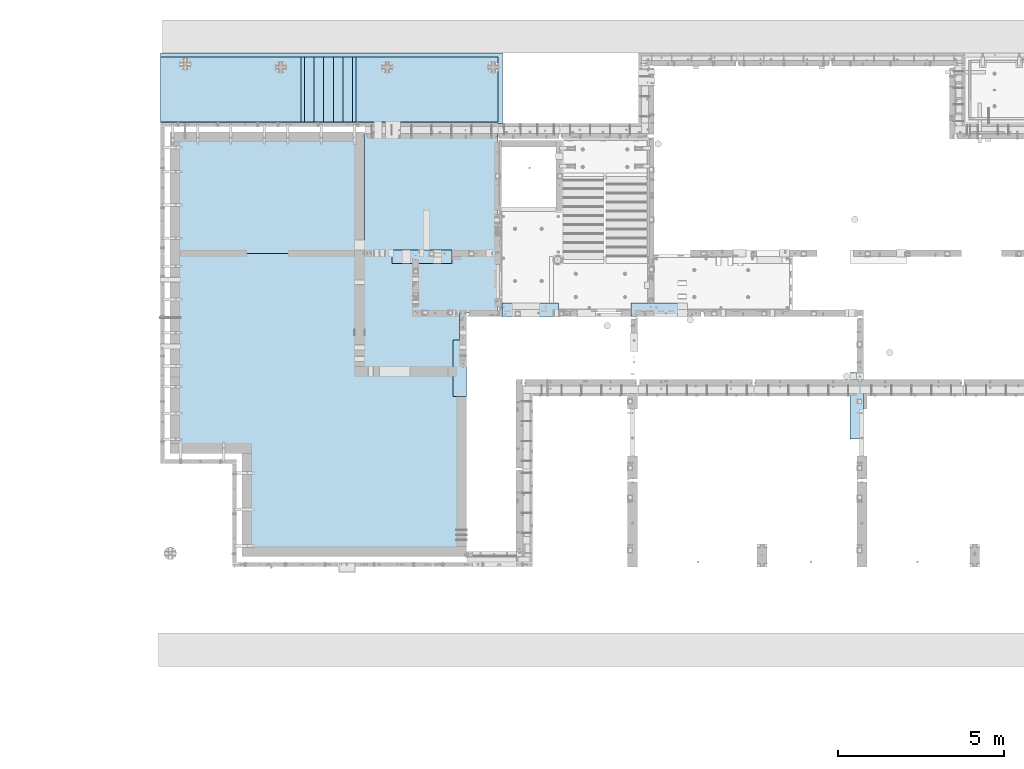
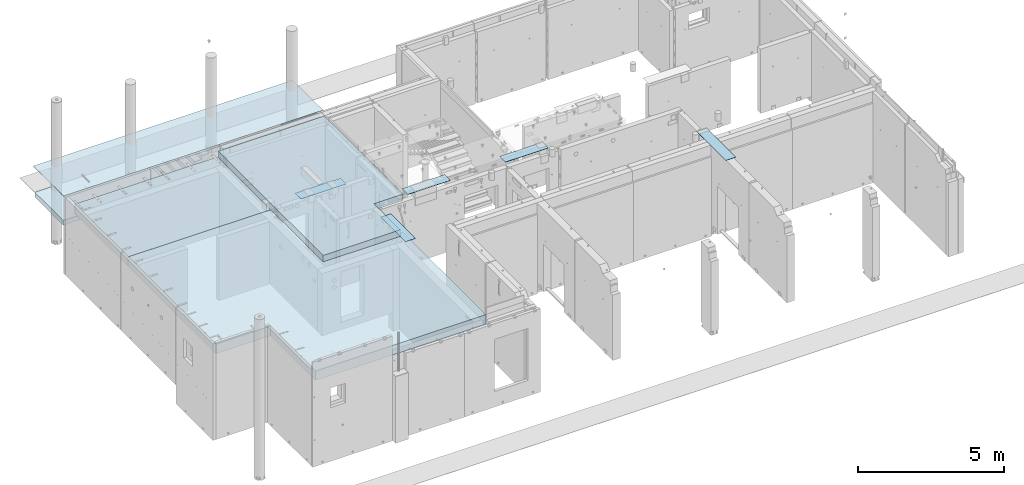
# One storey, part 147 of 264: 6 plates, 6 slabs, 12 elements without a shape of their own.
"""IFC2X3 building model written with IfcOpenShell, lengths in millimetres."""

from ifc_helpers import new_model, si_unit, frame, origin_with_axes, place, context, subcontext, project, spatial, faceted_brep, material, type_object, element, aggregate, save


model = new_model("IFC2X3")

# Units and contexts
model_context = context("Model", 3, precision=1e-05, world=origin_with_axes())
body_context = subcontext(model_context, "Body", "Model", "MODEL_VIEW")
ifc_project = project(units=[si_unit("LENGTHUNIT", "METRE", prefix="MILLI"), si_unit("AREAUNIT", "SQUARE_METRE"), si_unit("VOLUMEUNIT", "CUBIC_METRE"), si_unit("MASSUNIT", "GRAM", prefix="KILO"), si_unit("TIMEUNIT", "SECOND"), si_unit("PLANEANGLEUNIT", "RADIAN"), si_unit("SOLIDANGLEUNIT", "STERADIAN"), si_unit("THERMODYNAMICTEMPERATUREUNIT", "DEGREE_CELSIUS"), si_unit("LUMINOUSINTENSITYUNIT", "LUMEN")], contexts=[model_context])

# Site, building, storey
site_placement = place(None, origin_with_axes())
site = spatial("IfcSite", under=ifc_project, at=site_placement, CompositionType="ELEMENT")
building_placement = place(site_placement, origin_with_axes())
building = spatial("IfcBuilding", under=site, at=building_placement, CompositionType="ELEMENT")
storey_placement = place(building_placement, origin_with_axes())
storey = spatial("IfcBuildingStorey", under=building, at=storey_placement, Name="K", CompositionType="ELEMENT", Elevation=0.0)

# Assembly, plate
assembly_1_placement = place(storey_placement, origin_with_axes())
assembly_1 = element("IfcElementAssembly", 1, at=assembly_1_placement, inside=storey, Name="Steel Assembly", AssemblyPlace="NOTDEFINED", PredefinedType="NOTDEFINED")
ifc_material_1 = material()
plate_type_1 = type_object("IfcPlateType", PredefinedType="NOTDEFINED")
plate_1_placement = place(assembly_1_placement, frame((17842.0, 22999.95272079, 81715.0002235374), z_axis=(0.0, -0.999955292526699, 0.0094558419955201), x_axis=(-1.0, 3.00000001838171e-08, 0.0)))
plate_1 = element("IfcPlate", 2, at=plate_1_placement, type_object=plate_type_1, material=ifc_material_1, context=body_context, shape_type="Brep", body=[
    faceted_brep([(0.0, -5.0, 0.0), (0.00106528995092958, -5.0, 2115.09448242188), (0.00106528995092958, 5.0, 2115.09448242188), (0.0, 5.0, 0.0), (10282.0, -5.0, 2115.09448242188), (10282.0, 5.0, 2115.09448242188), (10282.0, -5.0, 0.0), (10282.0, 5.0, 3.63797880709171e-12)], [[[0, 1, 2, 3]], [[1, 4, 5, 2]], [[4, 6, 7, 5]], [[6, 0, 3, 7]], [[5, 7, 3, 2]], [[6, 4, 1, 0]]]),
])
aggregate(assembly_1, [plate_1])

# Assembly, slab
assembly_2_placement = place(storey_placement, origin_with_axes())
assembly_2 = element("IfcElementAssembly", 3, at=assembly_2_placement, inside=storey, Name="Assembly", AssemblyPlace="NOTDEFINED", PredefinedType="REINFORCEMENT_UNIT")
ifc_material_2 = material(Name="CONCRETE/Concrete_Undefined")
slab_type_1 = type_object("IfcSlabType", PredefinedType="NOTDEFINED")
slab_1_placement = place(assembly_2_placement, frame((11889.9993483948, 21907.9000655301, 80690.0), z_axis=(0.0, 0.0, -1.0), x_axis=(-1.0, 3.00000001838171e-08, 0.0)))
slab_1 = element("IfcSlab", 4, at=slab_1_placement, type_object=slab_type_1, material=ifc_material_2, Name="STAIRS", PredefinedType="FLOOR", context=body_context, shape_type="Brep", body=[
    faceted_brep([(0.0, -972.5, 0.0), (0.0, -972.5, -160.0), (1.81898940354586e-12, 972.5, -160.0), (1.81898940354586e-12, 972.5, 0.0), (-289.999267578125, -972.5, -160.0), (-289.999267578127, 972.500000000004, -160.0), (-289.999267578125, -972.5, -320.0), (-289.999267578127, 972.500000000004, -320.0), (-579.99853515625, -972.5, -320.0), (-579.99853515625, 972.500000000004, -320.0), (-579.99853515625, -972.5, -480.0), (-579.99853515625, 972.500000000004, -480.0), (-869.997802734373, -972.5, -480.0), (-869.997802734375, 972.5, -480.0), (-869.997802734373, -972.5, -640.0), (-869.997802734375, 972.5, -640.0), (-1159.9970703125, -972.5, -640.0), (-1159.9970703125, 972.500000000004, -640.0), (-1159.9970703125, -972.5, -800.0), (-1159.9970703125, 972.500000000004, -800.0), (-1449.99633789063, -972.5, -800.0), (-1449.99633789063, 972.5, -800.0), (-1449.99633789063, -972.5, -960.0), (-1449.99633789063, 972.5, -960.0), (-1549.99633789063, -972.5, -960.0), (-1549.99633789063, 972.5, -960.0), (-1549.99633789063, -972.5, -626.751770019531), (-1549.99633789063, 972.5, -626.751770019531), (-232.762039184568, -972.5, 100.0), (-232.762039184568, 972.500000000004, 100.0), (100.000000000002, -972.5, 100.0), (100.000000000002, 972.5, 100.0), (100.000000000002, -972.5, 0.0), (100.000000000002, 972.5, 0.0)], [[[0, 1, 2, 3]], [[1, 4, 5, 2]], [[4, 6, 7, 5]], [[6, 8, 9, 7]], [[8, 10, 11, 9]], [[10, 12, 13, 11]], [[12, 14, 15, 13]], [[14, 16, 17, 15]], [[16, 18, 19, 17]], [[18, 20, 21, 19]], [[20, 22, 23, 21]], [[22, 24, 25, 23]], [[24, 26, 27, 25]], [[26, 28, 29, 27]], [[28, 30, 31, 29]], [[30, 32, 33, 31]], [[32, 0, 3, 33]], [[5, 7, 9, 11, 13, 15, 17, 19, 21, 23, 25, 27, 29, 31, 33, 3, 2]], [[32, 30, 28, 26, 24, 22, 20, 18, 16, 14, 12, 10, 8, 6, 4, 1, 0]]]),
])
aggregate(assembly_2, [slab_1])

# Assembly, plate
assembly_3_placement = place(storey_placement, origin_with_axes())
assembly_3 = element("IfcElementAssembly", 5, at=assembly_3_placement, inside=storey, Name="Steel Assembly", AssemblyPlace="NOTDEFINED", PredefinedType="NOTDEFINED")
ifc_material_3 = material()
plate_type_2 = type_object("IfcPlateType", PredefinedType="NOTDEFINED")
plate_2_placement = place(assembly_3_placement, frame((17840.0, 15080.0, 81725.6000003815), z_axis=(0.0, 1.0, 0.0), x_axis=(1.0, 0.0, 0.0)))
plate_2 = element("IfcPlate", 6, at=plate_2_placement, type_object=plate_type_2, material=ifc_material_3, Name="YP", context=body_context, shape_type="Brep", body=[
    faceted_brep([(0.0, -5.0, 0.0), (0.0, -5.0, 400.0), (0.0, 5.0, 400.0), (0.0, 5.0, 0.0), (1699.99914550781, -5.0, 400.0), (1699.99914550781, 5.0, 400.0), (1699.99914550781, -5.0, 3.63797880709171e-12), (1699.99914550781, 5.0, 3.63797880709171e-12)], [[[0, 1, 2, 3]], [[1, 4, 5, 2]], [[4, 6, 7, 5]], [[6, 0, 3, 7]], [[5, 7, 3, 2]], [[6, 4, 1, 0]]]),
])
aggregate(assembly_3, [plate_2])

assembly_4_placement = place(storey_placement, origin_with_axes())
assembly_4 = element("IfcElementAssembly", 7, at=assembly_4_placement, inside=storey, Name="Steel Assembly", AssemblyPlace="NOTDEFINED", PredefinedType="NOTDEFINED")
plate_3_placement = place(assembly_4_placement, frame((21710.0, 15080.0, 81725.6000003815), z_axis=(0.0, 1.0, 0.0), x_axis=(1.0, 0.0, 0.0)))
plate_3 = element("IfcPlate", 8, at=plate_3_placement, type_object=plate_type_2, material=ifc_material_3, Name="YP", context=body_context, shape_type="Brep", body=[
    faceted_brep([(0.0, -5.0, 0.0), (0.0, -5.0, 400.0), (0.0, 5.0, 400.0), (0.0, 5.0, 0.0), (1699.99914550781, -5.0, 400.0), (1699.99914550781, 5.0, 400.0), (1699.99914550781, -5.0, 3.63797880709171e-12), (1699.99914550781, 5.0, 3.63797880709171e-12)], [[[0, 1, 2, 3]], [[1, 4, 5, 2]], [[4, 6, 7, 5]], [[6, 0, 3, 7]], [[5, 7, 3, 2]], [[6, 4, 1, 0]]]),
])
aggregate(assembly_4, [plate_3])

assembly_5_placement = place(storey_placement, origin_with_axes())
assembly_5 = element("IfcElementAssembly", 9, at=assembly_5_placement, inside=storey, Name="Steel Assembly", AssemblyPlace="NOTDEFINED", PredefinedType="NOTDEFINED")
plate_4_placement = place(assembly_5_placement, frame((14530.0, 16680.0, 81725.6000003815), z_axis=(0.0, 1.0, 0.0), x_axis=(1.0, 0.0, 0.0)))
plate_4 = element("IfcPlate", 10, at=plate_4_placement, type_object=plate_type_2, material=ifc_material_3, Name="YP", context=body_context, shape_type="Brep", body=[
    faceted_brep([(0.0, -5.0, 0.0), (0.0, -5.0, 400.0), (0.0, 5.0, 400.0), (0.0, 5.0, 0.0), (1799.99914550781, -5.0, 400.0), (1799.99914550781, 5.0, 400.0), (1799.99914550781, -5.0, 3.63797880709171e-12), (1799.99914550781, 5.0, 3.63797880709171e-12)], [[[0, 1, 2, 3]], [[1, 4, 5, 2]], [[4, 6, 7, 5]], [[6, 0, 3, 7]], [[5, 7, 3, 2]], [[6, 4, 1, 0]]]),
])
aggregate(assembly_5, [plate_4])

assembly_6_placement = place(storey_placement, origin_with_axes())
assembly_6 = element("IfcElementAssembly", 11, at=assembly_6_placement, inside=storey, Name="Steel Assembly", AssemblyPlace="NOTDEFINED", PredefinedType="NOTDEFINED")
plate_5_placement = place(assembly_6_placement, frame((28710.0, 11388.0, 81725.6000003815), z_axis=(-1.0, 3.00000001838171e-08, 0.0), x_axis=(0.0, 1.0, 0.0)))
plate_5 = element("IfcPlate", 12, at=plate_5_placement, type_object=plate_type_2, material=ifc_material_3, Name="YP", context=body_context, shape_type="Brep", body=[
    faceted_brep([(0.0, -5.0, 0.0), (0.0, -5.0, 400.0), (0.0, 5.0, 400.0), (0.0, 5.0, 0.0), (1999.99963378906, -5.0, 400.0), (1999.99963378906, 5.0, 400.0), (1999.99963378906, -5.0, 0.0), (1999.99963378906, 5.0, 0.0)], [[[0, 1, 2, 3]], [[1, 4, 5, 2]], [[4, 6, 7, 5]], [[6, 0, 3, 7]], [[5, 7, 3, 2]], [[6, 4, 1, 0]]]),
])
aggregate(assembly_6, [plate_5])

assembly_7_placement = place(storey_placement, origin_with_axes())
assembly_7 = element("IfcElementAssembly", 13, at=assembly_7_placement, inside=storey, Name="Steel Assembly", AssemblyPlace="NOTDEFINED", PredefinedType="NOTDEFINED")
plate_6_placement = place(assembly_7_placement, frame((16760.0, 12675.0, 81725.6000003815), z_axis=(-0.999999990476206, -0.000138013000065496, 0.0), x_axis=(-0.000138013000066464, 0.999999990476206, 0.0)))
plate_6 = element("IfcPlate", 14, at=plate_6_placement, type_object=plate_type_2, material=ifc_material_3, Name="YP", context=body_context, shape_type="Brep", body=[
    faceted_brep([(0.0, -5.0, 0.0), (0.0552374608814716, -5.0, 400.234619140625), (0.0552374608814716, 5.0, 400.234619140625), (0.0, 5.0, 0.0), (1700.05529785156, -5.0, 399.999999999998), (1700.05529785156, 5.0, 399.999999999998), (1700.00012207031, -5.0, 1.15687726065516e-09), (1700.00012207031, 5.0, 1.15687726065516e-09)], [[[0, 1, 2, 3]], [[1, 4, 5, 2]], [[4, 6, 7, 5]], [[6, 0, 3, 7]], [[5, 7, 3, 2]], [[6, 4, 1, 0]]]),
])
aggregate(assembly_7, [plate_6])

# Assembly, slab
assembly_8_placement = place(storey_placement, origin_with_axes())
assembly_8 = element("IfcElementAssembly", 15, at=assembly_8_placement, inside=storey, AssemblyPlace="NOTDEFINED", PredefinedType="REINFORCEMENT_UNIT")
slab_type_2 = type_object("IfcSlabType", PredefinedType="NOTDEFINED")
slab_2_placement = place(assembly_8_placement, frame((12208.7601086809, 22880.4000655301, 80590.0), z_axis=(0.0, -1.0, 0.0), x_axis=(-1.0, 3.00000001838171e-08, 0.0)))
slab_2 = element("IfcSlab", 16, at=slab_2_placement, type_object=slab_type_2, material=ifc_material_2, PredefinedType="FLOOR", context=body_context, shape_type="Brep", body=[
    faceted_brep([(418.760011883927, -100.0, 8.00355337560177e-11), (418.762007453937, -100.0, 1944.99981955335), (418.762007453937, 0.0, 1944.99981955335), (418.760011883929, 0.0, -0.000180445626028813), (0.000471908697363688, -100.0, 1945.00024920269), (0.000471809626105824, 0.0, 1945.00024920269), (-0.00152376038022339, 0.0, 0.000249203712883173), (0.000472005545816501, -100.0, 1945.3994140625), (4648.763671875, -100.0, 1945.39880371093), (4648.763671875, 100.0, 1945.39880371093), (0.000472005545816501, 100.0, 1945.3994140625), (4648.763671875, -100.0, 9.24046617001295e-10), (4648.763671875, 100.0, 9.24046617001295e-10), (0.0, 100.0, 0.0)], [[[0, 1, 2, 3]], [[4, 5, 2, 1]], [[6, 3, 2, 5]], [[7, 8, 9, 10]], [[8, 11, 12, 9]], [[9, 12, 13, 10]], [[4, 7, 10, 13, 6, 5]], [[0, 11, 8, 7, 4, 1]], [[13, 12, 11, 0, 3, 6]]]),
])
aggregate(assembly_8, [slab_2])

assembly_9_placement = place(storey_placement, origin_with_axes())
assembly_9 = element("IfcElementAssembly", 17, at=assembly_9_placement, inside=storey, AssemblyPlace="NOTDEFINED", PredefinedType="REINFORCEMENT_UNIT")
slab_3_placement = place(assembly_9_placement, frame((17720.0001086809, 22880.4000495535, 81550.0), z_axis=(0.0, -1.0, 0.0), x_axis=(-1.0, 3.00000001838171e-08, 0.0)))
slab_3 = element("IfcSlab", 18, at=slab_3_placement, type_object=slab_type_2, material=ifc_material_2, PredefinedType="FLOOR", context=body_context, shape_type="Brep", body=[
    faceted_brep([(4280.00363260356, -100.0, 0.000104388796899002), (4280.00363260357, 100.0, -6.78119249641895e-09), (4280.00564956835, 100.0, 1944.99879323152), (4280.00564956836, -100.0, 1944.99879323152), (0.0, -100.0, 0.0), (0.000493853753141593, -100.0, 1944.99938964844), (0.000493853753141593, 100.0, 1944.99938964844), (0.0, 100.0, 0.0)], [[[0, 1, 2, 3]], [[4, 5, 6, 7]], [[5, 4, 0, 3]], [[6, 5, 3, 2]], [[7, 6, 2, 1]], [[4, 7, 1, 0]]]),
])
aggregate(assembly_9, [slab_3])

assembly_10_placement = place(storey_placement, origin_with_axes())
assembly_10 = element("IfcElementAssembly", 19, at=assembly_10_placement, inside=storey, AssemblyPlace="NOTDEFINED", PredefinedType="REINFORCEMENT_UNIT")
ifc_material_4 = material(Name="CONCRETE/C30/37")
slab_type_3 = type_object("IfcSlabType", PredefinedType="NOTDEFINED")
slab_4_placement = place(assembly_10_placement, frame((13500.0033728411, 13375.0031738281, 81595.0), z_axis=(0.0, 1.0, 0.0), x_axis=(1.0, 0.0, 0.0)))
slab_4 = element("IfcSlab", 20, at=slab_4_placement, type_object=slab_type_3, material=ifc_material_4, PredefinedType="FLOOR", context=body_context, shape_type="Brep", body=[
    faceted_brep([(3059.99662716033, -135.0, 4.38376446254551e-10), (3059.99662716033, 135.0, 4.38376446254551e-10), (3059.99488714054, 135.0, 1804.99977600779), (3059.99488714054, -135.0, 1804.99977600779), (3159.99462890626, -135.0, 1804.99987240754), (3159.99462890625, 135.0, 1804.99987792969), (1.81898940354586e-12, -135.0, 1.81898940354586e-12), (-0.00694355741507025, -135.0, 7204.9970703125), (-0.00694355741507025, 135.0, 7204.9970703125), (1.81898940354586e-12, 135.0, 1.81898940354586e-12), (4209.99316406249, -135.0, 7205.0009765625), (4209.99316406249, 135.0, 7205.0009765625), (4209.9951171875, -135.0, 1805.00085449219), (4209.9951171875, 135.0, 1805.00085449219)], [[[0, 1, 2, 3]], [[4, 3, 2, 5]], [[6, 7, 8, 9]], [[7, 10, 11, 8]], [[10, 12, 13, 11]], [[12, 4, 5, 13]], [[1, 9, 8, 11, 13, 5, 2]], [[6, 9, 1, 0]], [[12, 10, 7, 6, 0, 3, 4]]]),
])
aggregate(assembly_10, [slab_4])

assembly_11_placement = place(storey_placement, origin_with_axes())
assembly_11 = element("IfcElementAssembly", 21, at=assembly_11_placement, inside=storey, AssemblyPlace="NOTDEFINED", PredefinedType="REINFORCEMENT_UNIT")
slab_type_4 = type_object("IfcSlabType", PredefinedType="NOTDEFINED")
slab_5_placement = place(assembly_11_placement, frame((13700.0033728411, 20630.0034224637, 81260.0), z_axis=(0.0, -1.0, 0.0), x_axis=(-1.0, 3.00000001838171e-08, 0.0)))
slab_5 = element("IfcSlab", 22, at=slab_5_placement, type_object=slab_type_4, material=ifc_material_2, PredefinedType="FLOOR", context=body_context, shape_type="Brep", body=[
    faceted_brep([(20.0019069322825, -200.0, 3650.00340795273), (20.0019069322825, 200.0, 3650.00340795273), (20.0018865974107, 200.0, 3613.00341243375), (20.0018865974107, -200.0, 3613.00341243375), (0.00187920178723289, -200.0, 3600.00342246317), (0.00187800653839076, 200.0, 3600.00342246317), (5850.00537109375, -200.0, 3650.00048828124), (5850.00341796875, -200.0, -1.58615875989199e-09), (5850.00341796875, 200.0, -1.58615875989199e-09), (5850.00537109375, 200.0, 3650.00048828124), (0.0, -200.0, -3.63797880709171e-12), (0.0, 200.0, -3.63797880709171e-12), (3.91517860407475e-05, -200.0, 75.0034224636547), (3.9126884075813e-05, 200.0, 75.0034224636547), (20.0000465474095, -200.0, 88.0034124342346), (20.0000465474095, 200.0, 88.0034124342346), (20.0000872171586, -200.0, 162.003412475162), (20.0000872171586, 200.0, 162.003412475162), (9.12936811801046e-05, -200.0, 175.003422186168), (9.12936811801046e-05, 200.0, 175.003422186168)], [[[0, 1, 2, 3]], [[4, 3, 2, 5]], [[6, 7, 8, 9]], [[7, 10, 11, 8]], [[11, 10, 12, 13]], [[12, 14, 15, 13]], [[16, 17, 15, 14]], [[18, 19, 17, 16]], [[19, 18, 4, 5]], [[1, 9, 8, 11, 13, 15, 17, 19, 5, 2]], [[6, 9, 1, 0]], [[18, 16, 14, 12, 10, 7, 6, 0, 3, 4]]]),
])
aggregate(assembly_11, [slab_5])

assembly_12_placement = place(storey_placement, origin_with_axes())
assembly_12 = element("IfcElementAssembly", 23, at=assembly_12_placement, inside=storey, AssemblyPlace="NOTDEFINED", PredefinedType="REINFORCEMENT_UNIT")
slab_type_5 = type_object("IfcSlabType", PredefinedType="NOTDEFINED")
slab_6_placement = place(assembly_12_placement, frame((13700.0033728411, 16980.0, 81260.0), z_axis=(0.0, -1.0, 0.0), x_axis=(-1.0, 3.00000001838171e-08, 0.0)))
slab_6 = element("IfcSlab", 24, at=slab_6_placement, type_object=slab_type_5, material=ifc_material_2, PredefinedType="FLOOR", context=body_context, shape_type="Brep", body=[
    faceted_brep([(-2907.99662685196, -199.999999999985, 3424.99990249712), (-2907.99662685196, 200.0, 3424.99990249712), (-2895.02979327163, 200.0, 3404.99982889551), (-2895.02979327163, -200.0, 3404.99982889551), (-3011.99662453879, -199.999999999985, 3424.99990020593), (-3011.99662453879, 200.0, 3424.99990020593), (-3024.99662908717, -200.0, 3404.99990054274), (-3024.9966290871, 200.0, 3404.99996369705), (0.0, -200.0, 3404.99682617188), (0.0, 200.0, 3404.99682617188), (0.0, 200.0, 49.9999997225241), (1.86874422070105e-06, -200.0, 49.9999997225241), (20.0000026513753, 200.000000000015, 37.0000004515168), (20.0000026513753, -200.0, 37.0000004515168), (20.0000016305003, -200.0, 0.0), (20.0000016305003, 200.0, 0.0), (5850.0029296875, 200.0, 0.0), (5850.0029296875, -200.0, 0.0), (5850.00341796875, -200.0, 6029.9970703125), (5850.00341796875, 200.0, 6029.9970703125), (3690.00341796875, -200.0, 6029.9970703125), (3690.00341796875, 200.0, 6029.9970703125), (3690.00341796875, -200.0, 9130.0029296875), (3690.00341796875, 200.0, 9130.0029296875), (-3059.99755859375, -200.0, 9130.0029296875), (-3059.99755859375, 200.0, 9130.0029296875), (-3059.99755859375, 200.0, 9105.00146018008), (-3059.99755859375, -200.0, 9105.00146018008), (-3039.99759208966, 200.0, 9092.00146090907), (-3039.99759208966, -200.0, 9092.00146090907), (-3039.9975941314, 200.0, 9018.00146086812), (-3039.9975941314, -200.0, 9018.00146086812), (-3059.99759474103, -200.0, 9005.00146045755), (-3059.99755859375, 200.0, 9005.00146045755), (-3059.99755859375, 200.0, 3405.0), (-3059.99755859375, -200.0, 3405.0)], [[[0, 1, 2, 3]], [[4, 5, 1, 0]], [[6, 7, 5, 4]], [[8, 9, 10, 11]], [[11, 10, 12, 13]], [[14, 13, 12, 15]], [[16, 17, 14, 15]], [[18, 17, 16, 19]], [[20, 18, 19, 21]], [[22, 20, 21, 23]], [[24, 22, 23, 25]], [[24, 25, 26, 27]], [[27, 26, 28, 29]], [[29, 28, 30, 31]], [[32, 31, 30, 33]], [[34, 35, 32, 33]], [[0, 3, 8, 11, 13, 14, 17, 18, 20, 22, 24, 27, 29, 31, 32, 35, 6, 4]], [[9, 8, 3, 2]], [[34, 33, 30, 28, 26, 25, 23, 21, 19, 16, 15, 12, 10, 9, 2, 1, 5, 7]], [[35, 34, 7, 6]]]),
])
aggregate(assembly_12, [slab_6])

save(model, "model.ifc")
